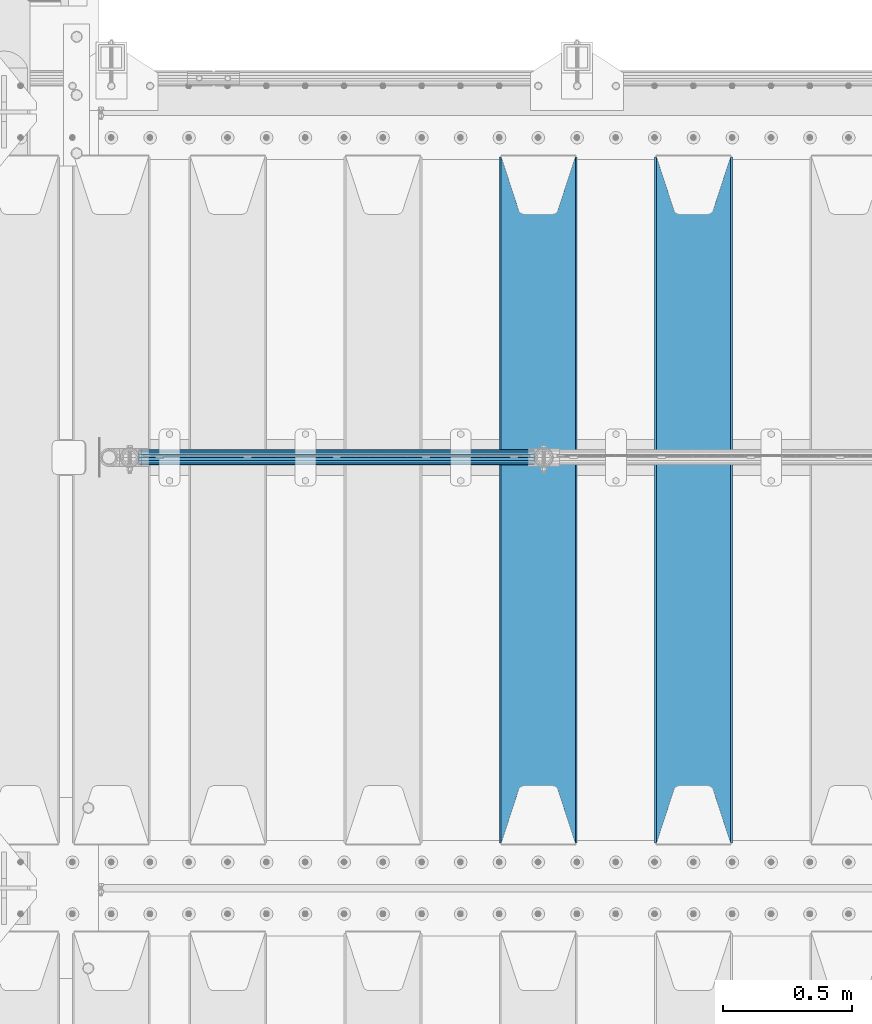
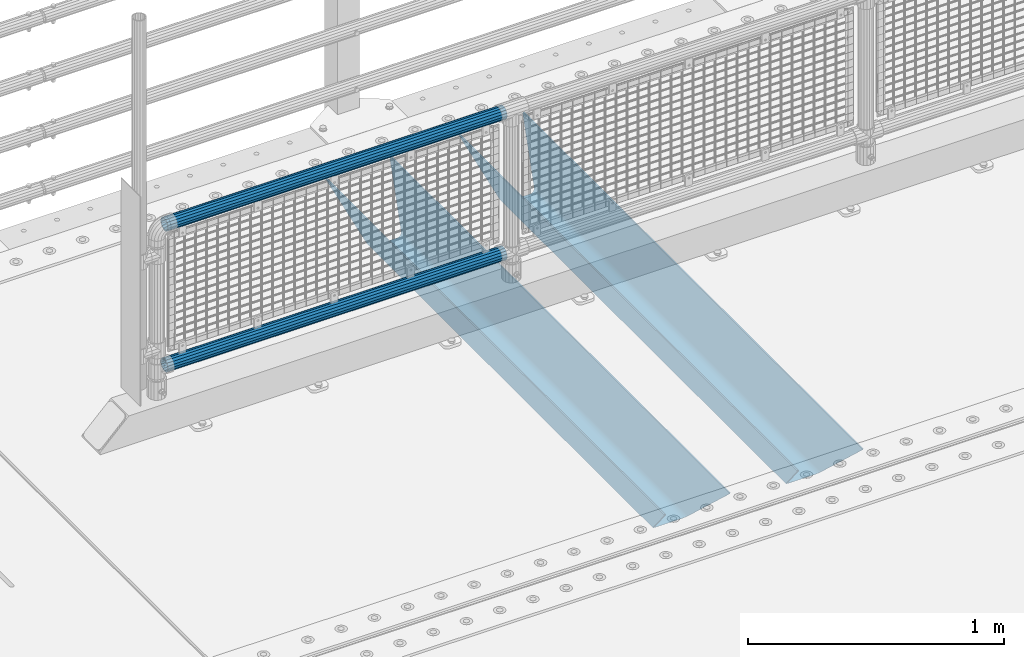
# One storey, part 94 of 208: 4 beams.
"""IFC2X3 building model written with IfcOpenShell, lengths in millimetres."""

from ifc_helpers import new_model, si_unit, frame, origin_with_axes, place, context, subcontext, project, spatial, faceted_brep, material, type_object, element, save


model = new_model("IFC2X3")

# Units and contexts
model_context = context("Model", 3, precision=1e-05, world=origin_with_axes())
body_context = subcontext(model_context, "Body", "Model", "MODEL_VIEW")
ifc_project = project(units=[si_unit("LENGTHUNIT", "METRE", prefix="MILLI"), si_unit("AREAUNIT", "SQUARE_METRE"), si_unit("VOLUMEUNIT", "CUBIC_METRE"), si_unit("MASSUNIT", "GRAM", prefix="KILO"), si_unit("TIMEUNIT", "SECOND"), si_unit("PLANEANGLEUNIT", "RADIAN"), si_unit("SOLIDANGLEUNIT", "STERADIAN"), si_unit("THERMODYNAMICTEMPERATUREUNIT", "DEGREE_CELSIUS"), si_unit("LUMINOUSINTENSITYUNIT", "LUMEN")], contexts=[model_context])

# Site, building, storey
site_placement = place(None, origin_with_axes())
site = spatial("IfcSite", under=ifc_project, at=site_placement, CompositionType="ELEMENT")
building_placement = place(site_placement, origin_with_axes())
building = spatial("IfcBuilding", under=site, at=building_placement, Name="Standard", CompositionType="ELEMENT")
storey_placement = place(building_placement, origin_with_axes())
storey = spatial("IfcBuildingStorey", under=building, at=storey_placement, Name="Undefined", CompositionType="ELEMENT", Elevation=0.0)

# Beams
ifc_material_1 = material(Name="STEEL/S355N")
beam_type_1 = type_object("IfcBeamType", PredefinedType="NOTDEFINED")
beam_1_placement = place(storey_placement, frame((-39650.0, 3175.0, -115.0), z_axis=(0.0, 0.0, 1.0), x_axis=(0.0, 1.0, 0.0)))
element("IfcBeam", 1, at=beam_1_placement, inside=storey, type_object=beam_type_1, material=ifc_material_1, context=body_context, shape_type="Brep", body=[
    faceted_brep([(0.0, 150.0, 115.0), (0.0, 143.689999999999, 115.0), (2650.00000000297, 143.689999999999, 115.0), (2650.00000000297, 150.0, 115.0), (2650.00000000297, 142.059565218402, 110.0000000031), (2650.00000000297, 148.369565218403, 110.0000000031), (2441.90079219208, -80.1103600731112, -98.0992078077845), (2437.7588105432, -77.5672621345584, -102.241189456673), (2434.06523489746, -74.4080125315522, -105.934765102404), (2430.91086095089, -70.710272125576, -109.089139048974), (2428.37322971128, -66.5649389910068, -111.626770288588), (2426.51472138055, -62.0739139532889, -113.485278619323), (2425.38102192091, -57.3475956567672, -114.618978078955), (2424.99999999987, -52.5021667386536, -115.0), (2424.99999999987, 52.5021667386536, -115.0), (2425.38102192091, 57.3475956567672, -114.618978078955), (2426.51472138055, 62.0739139532889, -113.485278619323), (2428.37322971128, 66.5649389910068, -111.626770288588), (2430.91086095089, 70.710272125576, -109.089139048974), (2434.06523489746, 74.4080125315522, -105.934765102404), (2437.7588105432, 77.5672621345584, -102.241189456673), (2441.90079219208, 80.1103600731112, -98.0992078077846), (2446.38936140511, 81.9747917625791, -93.6106385947584), (2448.24948500409, 76.2713538057251, -91.7505149957729), (2444.62967112262, 74.76777986261, -95.3703288772456), (2441.28936334126, 72.7168944282894, -98.710636658607), (2438.31067330438, 70.1691124903846, -101.689326695487), (2435.76682334747, 67.1870637758839, -104.233176652398), (2433.72034654133, 63.8440531834895, -106.279653458539), (2432.22154950041, 60.222258798236, -107.778450499454), (2431.30727574265, 56.4107117849089, -108.692724257221), (2430.99999999987, 52.5031078186876, -109.0), (2430.99999999987, -52.5031078186876, -109.0), (2431.30727574265, -56.4107117849089, -108.692724257221), (2432.22154950041, -60.222258798236, -107.778450499454), (2433.72034654133, -63.8440531834895, -106.279653458539), (2435.76682334747, -67.1870637758839, -104.233176652398), (2438.31067330438, -70.1691124903846, -101.689326695487), (2441.28936334126, -72.7168944282894, -98.7106366586071), (2444.62967112262, -74.76777986261, -95.3703288772457), (2448.24948500409, -76.2713538057251, -91.7505149957729), (2650.00000000297, -142.059565218402, 110.0000000031), (2650.00000000297, -148.369565218403, 110.0000000031), (2446.38936140511, -81.9747917625791, -93.6106385947584), (2650.00000000297, -143.689999999999, 115.0), (2650.00000000297, -150.0, 115.0), (0.0, -143.689999999999, 115.0), (0.0, -150.0, 115.0), (0.0, -148.369565218261, 110.000000002663), (203.610638597421, -81.9747917625791, -93.6106385947584), (208.099207810448, -80.1103600731112, -98.0992078077845), (212.241189459336, -77.5672621345584, -102.241189456673), (215.934765105067, -74.4080125315522, -105.934765102404), (219.089139051637, -70.710272125576, -109.089139048974), (221.626770291251, -66.5649389910068, -111.626770288588), (223.485278621986, -62.0739139532889, -113.485278619323), (224.618978081618, -57.3475956567672, -114.618978078955), (225.000000002663, -52.5021667386536, -115.0), (225.000000002663, 52.5021667386536, -115.0), (224.618978081618, 57.3475956567672, -114.618978078955), (223.485278621986, 62.0739139532889, -113.485278619323), (221.626770291251, 66.5649389910068, -111.626770288588), (219.089139051637, 70.710272125576, -109.089139048974), (215.934765105067, 74.4080125315522, -105.934765102404), (212.241189459336, 77.5672621345584, -102.241189456673), (208.099207810448, 80.1103600731112, -98.0992078077846), (203.610638597421, 81.9747917625791, -93.6106385947584), (0.0, 148.369565218261, 110.000000002663), (0.0, 142.05956521826, 110.000000002663), (201.750514998436, 76.2713538057251, -91.7505149957729), (205.370328879908, 74.76777986261, -95.3703288772456), (208.71063666127, 72.7168944282894, -98.710636658607), (211.68932669815, 70.1691124903846, -101.689326695487), (214.233176655061, 67.1870637758839, -104.233176652398), (216.279653461202, 63.8440531834895, -106.279653458539), (217.778450502116, 60.222258798236, -107.778450499454), (218.692724259884, 56.4107117849089, -108.692724257221), (219.000000002663, 52.5031078186876, -109.0), (219.000000002663, -52.5031078186876, -109.0), (218.692724259884, -56.4107117849089, -108.692724257221), (217.778450502116, -60.222258798236, -107.778450499454), (216.279653461202, -63.8440531834895, -106.279653458539), (214.233176655061, -67.1870637758839, -104.233176652398), (211.68932669815, -70.1691124903846, -101.689326695487), (208.71063666127, -72.7168944282894, -98.7106366586071), (205.370328879908, -74.76777986261, -95.3703288772457), (201.750514998436, -76.2713538057251, -91.7505149957729), (0.0, -142.05956521826, 110.000000002663)], [[[0, 1, 2, 3]], [[3, 2, 4, 5]], [[6, 7, 8, 9, 10, 11, 12, 13, 14, 15, 16, 17, 18, 19, 20, 21, 22, 5, 4, 23, 24, 25, 26, 27, 28, 29, 30, 31, 32, 33, 34, 35, 36, 37, 38, 39, 40, 41, 42, 43]], [[44, 45, 42, 41]], [[46, 47, 45, 44]], [[43, 42, 45, 47, 48, 49]], [[6, 43, 49, 50]], [[7, 6, 50, 51]], [[8, 7, 51, 52]], [[9, 8, 52, 53]], [[10, 9, 53, 54]], [[11, 10, 54, 55]], [[12, 11, 55, 56]], [[13, 12, 56, 57]], [[14, 13, 57, 58]], [[15, 14, 58, 59]], [[16, 15, 59, 60]], [[17, 16, 60, 61]], [[18, 17, 61, 62]], [[19, 18, 62, 63]], [[20, 19, 63, 64]], [[21, 20, 64, 65]], [[22, 21, 65, 66]], [[0, 3, 5, 22, 66, 67]], [[1, 0, 67, 68]], [[23, 4, 2, 1, 68, 69]], [[24, 23, 69, 70]], [[25, 24, 70, 71]], [[26, 25, 71, 72]], [[27, 26, 72, 73]], [[28, 27, 73, 74]], [[29, 28, 74, 75]], [[30, 29, 75, 76]], [[31, 30, 76, 77]], [[32, 31, 77, 78]], [[33, 32, 78, 79]], [[34, 33, 79, 80]], [[35, 34, 80, 81]], [[36, 35, 81, 82]], [[37, 36, 82, 83]], [[38, 37, 83, 84]], [[39, 38, 84, 85]], [[40, 39, 85, 86]], [[46, 44, 41, 40, 86, 87]], [[47, 46, 87, 48]], [[86, 85, 84, 83, 82, 81, 80, 79, 78, 77, 76, 75, 74, 73, 72, 71, 70, 69, 68, 67, 66, 65, 64, 63, 62, 61, 60, 59, 58, 57, 56, 55, 54, 53, 52, 51, 50, 49, 48, 87]]]),
])
beam_2_placement = place(storey_placement, frame((-40250.0, 3175.0, -115.0), z_axis=(0.0, 0.0, 1.0), x_axis=(0.0, 1.0, 0.0)))
element("IfcBeam", 2, at=beam_2_placement, inside=storey, type_object=beam_type_1, material=ifc_material_1, context=body_context, shape_type="Brep", body=[
    faceted_brep([(0.0, 150.0, 115.0), (0.0, 143.689999999999, 115.0), (2650.00000000297, 143.689999999999, 115.0), (2650.00000000297, 150.0, 115.0), (2650.00000000297, 142.059565218402, 110.0000000031), (2650.00000000297, 148.369565218403, 110.0000000031), (2441.90079219208, -80.1103600731112, -98.0992078077845), (2437.7588105432, -77.5672621345584, -102.241189456673), (2434.06523489746, -74.4080125315522, -105.934765102404), (2430.91086095089, -70.710272125576, -109.089139048974), (2428.37322971128, -66.5649389910068, -111.626770288588), (2426.51472138055, -62.0739139532889, -113.485278619323), (2425.38102192091, -57.3475956567672, -114.618978078955), (2424.99999999987, -52.5021667386536, -115.0), (2424.99999999987, 52.5021667386536, -115.0), (2425.38102192091, 57.3475956567672, -114.618978078955), (2426.51472138055, 62.0739139532889, -113.485278619323), (2428.37322971128, 66.5649389910068, -111.626770288588), (2430.91086095089, 70.710272125576, -109.089139048974), (2434.06523489746, 74.4080125315522, -105.934765102404), (2437.7588105432, 77.5672621345584, -102.241189456673), (2441.90079219208, 80.1103600731112, -98.0992078077846), (2446.38936140511, 81.9747917625791, -93.6106385947584), (2448.24948500409, 76.2713538057251, -91.7505149957729), (2444.62967112262, 74.76777986261, -95.3703288772456), (2441.28936334126, 72.7168944282894, -98.710636658607), (2438.31067330438, 70.1691124903846, -101.689326695487), (2435.76682334747, 67.1870637758839, -104.233176652398), (2433.72034654133, 63.8440531834895, -106.279653458539), (2432.22154950041, 60.222258798236, -107.778450499454), (2431.30727574265, 56.4107117849089, -108.692724257221), (2430.99999999987, 52.5031078186876, -109.0), (2430.99999999987, -52.5031078186876, -109.0), (2431.30727574265, -56.4107117849089, -108.692724257221), (2432.22154950041, -60.222258798236, -107.778450499454), (2433.72034654133, -63.8440531834895, -106.279653458539), (2435.76682334747, -67.1870637758839, -104.233176652398), (2438.31067330438, -70.1691124903846, -101.689326695487), (2441.28936334126, -72.7168944282894, -98.7106366586071), (2444.62967112262, -74.76777986261, -95.3703288772457), (2448.24948500409, -76.2713538057251, -91.7505149957729), (2650.00000000297, -142.059565218402, 110.0000000031), (2650.00000000297, -148.369565218403, 110.0000000031), (2446.38936140511, -81.9747917625791, -93.6106385947584), (2650.00000000297, -143.689999999999, 115.0), (2650.00000000297, -150.0, 115.0), (0.0, -143.689999999999, 115.0), (0.0, -150.0, 115.0), (0.0, -148.369565218261, 110.000000002663), (203.610638597421, -81.9747917625791, -93.6106385947584), (208.099207810448, -80.1103600731112, -98.0992078077845), (212.241189459336, -77.5672621345584, -102.241189456673), (215.934765105067, -74.4080125315522, -105.934765102404), (219.089139051637, -70.710272125576, -109.089139048974), (221.626770291251, -66.5649389910068, -111.626770288588), (223.485278621986, -62.0739139532889, -113.485278619323), (224.618978081618, -57.3475956567672, -114.618978078955), (225.000000002663, -52.5021667386536, -115.0), (225.000000002663, 52.5021667386536, -115.0), (224.618978081618, 57.3475956567672, -114.618978078955), (223.485278621986, 62.0739139532889, -113.485278619323), (221.626770291251, 66.5649389910068, -111.626770288588), (219.089139051637, 70.710272125576, -109.089139048974), (215.934765105067, 74.4080125315522, -105.934765102404), (212.241189459336, 77.5672621345584, -102.241189456673), (208.099207810448, 80.1103600731112, -98.0992078077846), (203.610638597421, 81.9747917625791, -93.6106385947584), (0.0, 148.369565218261, 110.000000002663), (0.0, 142.05956521826, 110.000000002663), (201.750514998436, 76.2713538057251, -91.7505149957729), (205.370328879908, 74.76777986261, -95.3703288772456), (208.71063666127, 72.7168944282894, -98.710636658607), (211.68932669815, 70.1691124903846, -101.689326695487), (214.233176655061, 67.1870637758839, -104.233176652398), (216.279653461202, 63.8440531834895, -106.279653458539), (217.778450502116, 60.222258798236, -107.778450499454), (218.692724259884, 56.4107117849089, -108.692724257221), (219.000000002663, 52.5031078186876, -109.0), (219.000000002663, -52.5031078186876, -109.0), (218.692724259884, -56.4107117849089, -108.692724257221), (217.778450502116, -60.222258798236, -107.778450499454), (216.279653461202, -63.8440531834895, -106.279653458539), (214.233176655061, -67.1870637758839, -104.233176652398), (211.68932669815, -70.1691124903846, -101.689326695487), (208.71063666127, -72.7168944282894, -98.7106366586071), (205.370328879908, -74.76777986261, -95.3703288772457), (201.750514998436, -76.2713538057251, -91.7505149957729), (0.0, -142.05956521826, 110.000000002663)], [[[0, 1, 2, 3]], [[3, 2, 4, 5]], [[6, 7, 8, 9, 10, 11, 12, 13, 14, 15, 16, 17, 18, 19, 20, 21, 22, 5, 4, 23, 24, 25, 26, 27, 28, 29, 30, 31, 32, 33, 34, 35, 36, 37, 38, 39, 40, 41, 42, 43]], [[44, 45, 42, 41]], [[46, 47, 45, 44]], [[43, 42, 45, 47, 48, 49]], [[6, 43, 49, 50]], [[7, 6, 50, 51]], [[8, 7, 51, 52]], [[9, 8, 52, 53]], [[10, 9, 53, 54]], [[11, 10, 54, 55]], [[12, 11, 55, 56]], [[13, 12, 56, 57]], [[14, 13, 57, 58]], [[15, 14, 58, 59]], [[16, 15, 59, 60]], [[17, 16, 60, 61]], [[18, 17, 61, 62]], [[19, 18, 62, 63]], [[20, 19, 63, 64]], [[21, 20, 64, 65]], [[22, 21, 65, 66]], [[0, 3, 5, 22, 66, 67]], [[1, 0, 67, 68]], [[23, 4, 2, 1, 68, 69]], [[24, 23, 69, 70]], [[25, 24, 70, 71]], [[26, 25, 71, 72]], [[27, 26, 72, 73]], [[28, 27, 73, 74]], [[29, 28, 74, 75]], [[30, 29, 75, 76]], [[31, 30, 76, 77]], [[32, 31, 77, 78]], [[33, 32, 78, 79]], [[34, 33, 79, 80]], [[35, 34, 80, 81]], [[36, 35, 81, 82]], [[37, 36, 82, 83]], [[38, 37, 83, 84]], [[39, 38, 84, 85]], [[40, 39, 85, 86]], [[46, 44, 41, 40, 86, 87]], [[47, 46, 87, 48]], [[86, 85, 84, 83, 82, 81, 80, 79, 78, 77, 76, 75, 74, 73, 72, 71, 70, 69, 68, 67, 66, 65, 64, 63, 62, 61, 60, 59, 58, 57, 56, 55, 54, 53, 52, 51, 50, 49, 48, 87]]]),
])
ifc_material_2 = material()
beam_type_2 = type_object("IfcBeamType", PredefinedType="NOTDEFINED")
beam_3_placement = place(storey_placement, frame((-41794.15, 4664.5, 969.849999999999), z_axis=(0.0, 0.0, 1.0), x_axis=(1.0, 0.0, 0.0)))
element("IfcBeam", 3, at=beam_3_placement, inside=storey, type_object=beam_type_2, material=ifc_material_2, context=body_context, shape_type="Brep", body=[
    faceted_brep([(0.0, -25.3500000000004, 0.0), (0.0, -23.4203461491616, 9.70102501045403), (1530.0, -23.4203461491616, 9.70102501045506), (1530.0, -25.3500000000004, 0.0), (0.0, -17.9251569030794, 17.9251569030785), (1530.0, -17.9251569030794, 17.925156903079), (0.0, -9.70102501045494, 23.4203461491597), (1530.0, -9.70102501045494, 23.4203461491611), (0.0, 0.0, 25.3499999999985), (1530.0, 0.0, 25.35), (0.0, 9.70102501045494, 23.4203461491597), (1530.0, 9.70102501045494, 23.4203461491611), (0.0, 17.9251569030794, 17.9251569030785), (1530.0, 17.9251569030794, 17.925156903079), (0.0, 23.4203461491616, 9.70102501045403), (1530.0, 23.4203461491616, 9.701025010455), (0.0, 25.3500000000004, 0.0), (1530.0, 25.3500000000004, 0.0), (0.0, 23.4203461491616, -9.70102501045403), (1530.0, 23.4203461491616, -9.70102501045506), (0.0, 17.9251569030794, -17.9251569030785), (1530.0, 17.9251569030794, -17.925156903079), (0.0, 9.70102501045494, -23.4203461491597), (1530.0, 9.70102501045494, -23.4203461491611), (0.0, 0.0, -25.3499999999985), (1530.0, 0.0, -25.35), (0.0, -9.70102501045494, -23.4203461491597), (1530.0, -9.70102501045494, -23.4203461491611), (0.0, -17.9251569030794, -17.9251569030785), (1530.0, -17.9251569030794, -17.925156903079), (0.0, -23.4203461491616, -9.70102501045403), (1530.0, -23.4203461491616, -9.701025010455), (0.0, -30.1499999999996, 0.0), (0.0, -27.8549679052148, -11.5379054858058), (1530.0, -27.8549679052148, -11.5379054858075), (1530.0, -30.1499999999996, 0.0), (0.0, -21.3192694527743, -21.3192694527752), (1530.0, -21.3192694527743, -21.3192694527744), (0.0, -11.5379054858076, -27.8549679052157), (1530.0, -11.5379054858076, -27.8549679052153), (0.0, 0.0, -30.1500000000015), (1530.0, 0.0, -30.15), (0.0, 11.5379054858076, -27.8549679052157), (1530.0, 11.5379054858076, -27.8549679052153), (0.0, 21.3192694527743, -21.3192694527752), (1530.0, 21.3192694527743, -21.3192694527744), (0.0, 27.8549679052157, -11.5379054858058), (1530.0, 27.8549679052157, -11.5379054858075), (0.0, 30.1499999999996, 0.0), (1530.0, 30.1499999999996, 0.0), (0.0, 27.8549679052157, 11.5379054858058), (1530.0, 27.8549679052157, 11.5379054858075), (0.0, 21.3192694527743, 21.3192694527752), (1530.0, 21.3192694527743, 21.3192694527744), (0.0, 11.5379054858076, 27.8549679052157), (1530.0, 11.5379054858076, 27.8549679052153), (0.0, 0.0, 30.1500000000015), (1530.0, 0.0, 30.15), (0.0, -11.5379054858076, 27.8549679052157), (1530.0, -11.5379054858076, 27.8549679052153), (0.0, -21.3192694527743, 21.3192694527752), (1530.0, -21.3192694527743, 21.3192694527744), (0.0, -27.8549679052157, 11.5379054858058), (1530.0, -27.8549679052157, 11.5379054858075)], [[[0, 1, 2, 3]], [[1, 4, 5, 2]], [[4, 6, 7, 5]], [[6, 8, 9, 7]], [[8, 10, 11, 9]], [[10, 12, 13, 11]], [[12, 14, 15, 13]], [[14, 16, 17, 15]], [[16, 18, 19, 17]], [[18, 20, 21, 19]], [[20, 22, 23, 21]], [[22, 24, 25, 23]], [[24, 26, 27, 25]], [[26, 28, 29, 27]], [[28, 30, 31, 29]], [[30, 0, 3, 31]], [[32, 33, 34, 35]], [[33, 36, 37, 34]], [[36, 38, 39, 37]], [[38, 40, 41, 39]], [[40, 42, 43, 41]], [[42, 44, 45, 43]], [[44, 46, 47, 45]], [[46, 48, 49, 47]], [[48, 50, 51, 49]], [[50, 52, 53, 51]], [[52, 54, 55, 53]], [[54, 56, 57, 55]], [[56, 58, 59, 57]], [[58, 60, 61, 59]], [[60, 62, 63, 61]], [[62, 32, 35, 63]], [[37, 39, 41, 43, 45, 47, 49, 51, 53, 55, 57, 59, 61, 63, 35, 34], [5, 7, 9, 11, 13, 15, 17, 19, 21, 23, 25, 27, 29, 31, 3, 2]], [[62, 60, 58, 56, 54, 52, 50, 48, 46, 44, 42, 40, 38, 36, 33, 32], [30, 28, 26, 24, 22, 20, 18, 16, 14, 12, 10, 8, 6, 4, 1, 0]]]),
])
beam_4_placement = place(storey_placement, frame((-41794.15, 4664.5, 298.170000000001), z_axis=(0.0, 0.0, 1.0), x_axis=(1.0, 0.0, 0.0)))
element("IfcBeam", 4, at=beam_4_placement, inside=storey, type_object=beam_type_2, material=ifc_material_2, context=body_context, shape_type="Brep", body=[
    faceted_brep([(0.0, -25.3500000000004, 0.0), (0.0, -23.4203461491616, 9.70102501045403), (1530.0, -23.4203461491616, 9.70102501045506), (1530.0, -25.3500000000004, 0.0), (0.0, -17.9251569030794, 17.9251569030785), (1530.0, -17.9251569030794, 17.925156903079), (0.0, -9.70102501045494, 23.4203461491597), (1530.0, -9.70102501045494, 23.4203461491611), (0.0, 0.0, 25.3499999999985), (1530.0, 0.0, 25.35), (0.0, 9.70102501045494, 23.4203461491597), (1530.0, 9.70102501045494, 23.4203461491611), (0.0, 17.9251569030794, 17.9251569030785), (1530.0, 17.9251569030794, 17.925156903079), (0.0, 23.4203461491616, 9.70102501045403), (1530.0, 23.4203461491616, 9.701025010455), (0.0, 25.3500000000004, 0.0), (1530.0, 25.3500000000004, 0.0), (0.0, 23.4203461491616, -9.70102501045403), (1530.0, 23.4203461491616, -9.70102501045506), (0.0, 17.9251569030794, -17.9251569030785), (1530.0, 17.9251569030794, -17.925156903079), (0.0, 9.70102501045494, -23.4203461491597), (1530.0, 9.70102501045494, -23.4203461491611), (0.0, 0.0, -25.3499999999985), (1530.0, 0.0, -25.35), (0.0, -9.70102501045494, -23.4203461491597), (1530.0, -9.70102501045494, -23.4203461491611), (0.0, -17.9251569030794, -17.9251569030785), (1530.0, -17.9251569030794, -17.925156903079), (0.0, -23.4203461491616, -9.70102501045403), (1530.0, -23.4203461491616, -9.701025010455), (0.0, -30.1499999999996, 0.0), (0.0, -27.8549679052148, -11.5379054858058), (1530.0, -27.8549679052148, -11.5379054858075), (1530.0, -30.1499999999996, 0.0), (0.0, -21.3192694527743, -21.3192694527752), (1530.0, -21.3192694527743, -21.3192694527744), (0.0, -11.5379054858076, -27.8549679052157), (1530.0, -11.5379054858076, -27.8549679052153), (0.0, 0.0, -30.1500000000015), (1530.0, 0.0, -30.15), (0.0, 11.5379054858076, -27.8549679052157), (1530.0, 11.5379054858076, -27.8549679052153), (0.0, 21.3192694527743, -21.3192694527752), (1530.0, 21.3192694527743, -21.3192694527744), (0.0, 27.8549679052157, -11.5379054858058), (1530.0, 27.8549679052157, -11.5379054858075), (0.0, 30.1499999999996, 0.0), (1530.0, 30.1499999999996, 0.0), (0.0, 27.8549679052157, 11.5379054858058), (1530.0, 27.8549679052157, 11.5379054858075), (0.0, 21.3192694527743, 21.3192694527752), (1530.0, 21.3192694527743, 21.3192694527744), (0.0, 11.5379054858076, 27.8549679052157), (1530.0, 11.5379054858076, 27.8549679052153), (0.0, 0.0, 30.1500000000015), (1530.0, 0.0, 30.15), (0.0, -11.5379054858076, 27.8549679052157), (1530.0, -11.5379054858076, 27.8549679052153), (0.0, -21.3192694527743, 21.3192694527752), (1530.0, -21.3192694527743, 21.3192694527744), (0.0, -27.8549679052157, 11.5379054858058), (1530.0, -27.8549679052157, 11.5379054858075)], [[[0, 1, 2, 3]], [[1, 4, 5, 2]], [[4, 6, 7, 5]], [[6, 8, 9, 7]], [[8, 10, 11, 9]], [[10, 12, 13, 11]], [[12, 14, 15, 13]], [[14, 16, 17, 15]], [[16, 18, 19, 17]], [[18, 20, 21, 19]], [[20, 22, 23, 21]], [[22, 24, 25, 23]], [[24, 26, 27, 25]], [[26, 28, 29, 27]], [[28, 30, 31, 29]], [[30, 0, 3, 31]], [[32, 33, 34, 35]], [[33, 36, 37, 34]], [[36, 38, 39, 37]], [[38, 40, 41, 39]], [[40, 42, 43, 41]], [[42, 44, 45, 43]], [[44, 46, 47, 45]], [[46, 48, 49, 47]], [[48, 50, 51, 49]], [[50, 52, 53, 51]], [[52, 54, 55, 53]], [[54, 56, 57, 55]], [[56, 58, 59, 57]], [[58, 60, 61, 59]], [[60, 62, 63, 61]], [[62, 32, 35, 63]], [[37, 39, 41, 43, 45, 47, 49, 51, 53, 55, 57, 59, 61, 63, 35, 34], [5, 7, 9, 11, 13, 15, 17, 19, 21, 23, 25, 27, 29, 31, 3, 2]], [[62, 60, 58, 56, 54, 52, 50, 48, 46, 44, 42, 40, 38, 36, 33, 32], [30, 28, 26, 24, 22, 20, 18, 16, 14, 12, 10, 8, 6, 4, 1, 0]]]),
])

save(model, "model.ifc")
